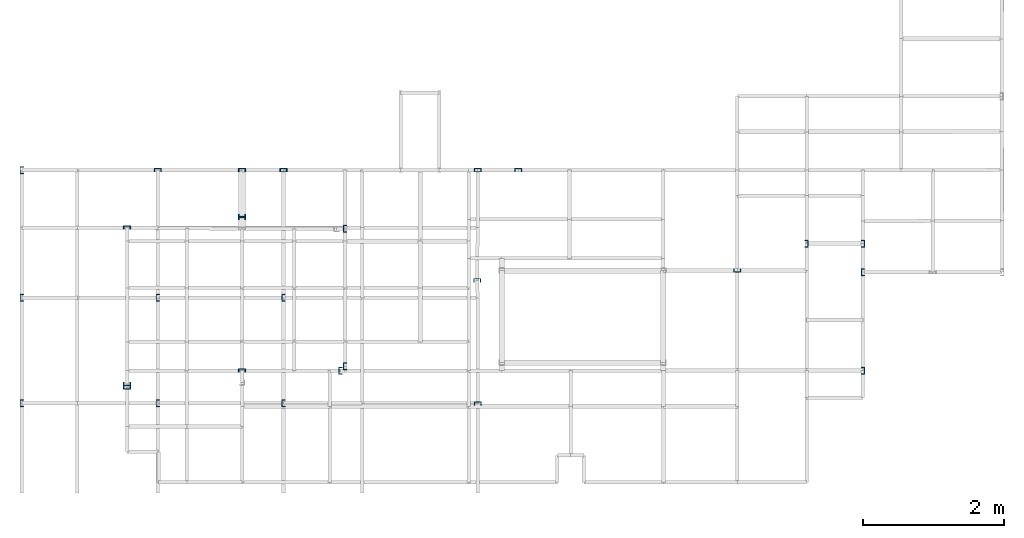
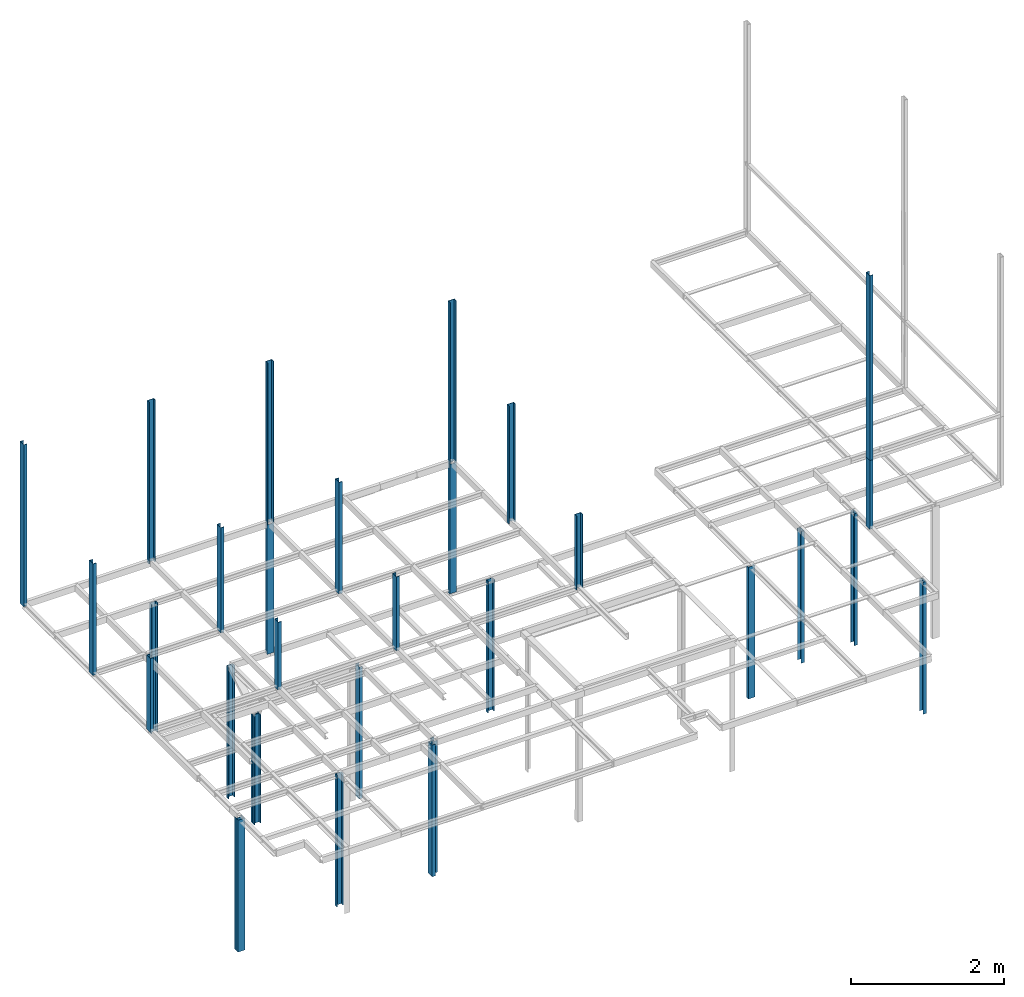
# Not in any storey, part 1 of 7: 31 columns.
"""IFC2X3 model written with IfcOpenShell, lengths in centimetres."""

from ifc_helpers import new_model, si_unit, frame, frame_2d, origin_with_axes, origin_2d_with_axis, place, context, project, u_section, extrude, material, element, save


model = new_model("IFC2X3")

# Units and contexts
model_context = context("Model", 3, precision=1e-05, world=origin_with_axes())
plan_context = context("Plan", 3, precision=1e-05, world=origin_with_axes())
ifc_project = project(units=[si_unit("LENGTHUNIT", "METRE", prefix="CENTI"), si_unit("AREAUNIT", "SQUARE_METRE", prefix="CENTI"), si_unit("VOLUMEUNIT", "CUBIC_METRE", prefix="CENTI"), si_unit("PLANEANGLEUNIT", "RADIAN"), si_unit("SOLIDANGLEUNIT", "STERADIAN"), si_unit("MASSUNIT", "GRAM"), si_unit("TIMEUNIT", "SECOND"), si_unit("THERMODYNAMICTEMPERATUREUNIT", "DEGREE_CELSIUS"), si_unit("LUMINOUSINTENSITYUNIT", "LUMEN")], contexts=[model_context, plan_context])

# Columns
ifc_material = material()
for number, where, z_axis, x_axis, name in (
    (1, (-589.100036621094, 275.0, 0.0), (0.0, 0.0, 1.0), (0.0, -1.0, 0.0), "UPN - de ala Pilar:UPN 100"),
    (2, (-197.5, 275.0, 0.0), (0.0, 0.0, 1.0), (0.0, -1.0, 0.0), "UPN - de ala Pilar:UPN 100"),
):
    element("IfcColumn", number, at=place(None, frame(where, z_axis=z_axis, x_axis=x_axis)), material=ifc_material, Name=name, context=model_context, shape_type="SweptSolid", body=[
        extrude(u_section(Depth=10.0, FlangeWidth=5.0, WebThickness=0.6, FlangeThickness=0.85, FilletRadius=0.0, EdgeRadius=0.0, FlangeSlope=0.0, CentreOfGravityInX=0.0, at=origin_2d_with_axis()), origin_with_axes(), (0.0, 0.0, 1.0), 210.0),
    ])
for number, where, z_axis, x_axis, name in (
    (3, (-589.100036621094, 210.199996948242, 0.0), (0.0, 0.0, 1.0), (0.0, 1.0, 0.0), "UPN - de ala Pilar:UPN 100"),
    (4, (-589.100036621094, 207.100006103516, 0.0), (0.0, 0.0, 1.0), (0.0, -1.0, 0.0), "UPN - de ala Pilar:UPN 100"),
):
    element("IfcColumn", number, at=place(None, frame(where, z_axis=z_axis, x_axis=x_axis)), material=ifc_material, Name=name, context=model_context, shape_type="SweptSolid", body=[
        extrude(u_section(Depth=10.0, FlangeWidth=5.0, WebThickness=0.6, FlangeThickness=0.85, FilletRadius=0.0, EdgeRadius=0.0, FlangeSlope=0.0, CentreOfGravityInX=0.0, at=origin_2d_with_axis()), origin_with_axes(), (0.0, 0.0, 1.0), 173.0),
    ])
for number, where, z_axis, x_axis, name in (
    (5, (-443.100006103516, 192.0, 0.0), (0.0, 0.0, 1.0), (1.0, 0.0, 0.0), "UPN - de ala Pilar:UPN 100"),
    (6, (211.100006103516, 171.0, 0.0), (0.0, 0.0, 1.0), (-1.0, 0.0, 0.0), "UPN - de ala Pilar:UPN 100"),
    (7, (291.100006103516, 171.0, 0.0), (0.0, 0.0, 1.0), (-1.0, 0.0, 0.0), "UPN - de ala Pilar:UPN 100"),
    (8, (113.099998474121, 132.699996948242, 0.0), (0.0, 0.0, 1.0), (0.0, 1.0, 0.0), "UPN - de ala Pilar:UPN 100"),
):
    element("IfcColumn", number, at=place(None, frame(where, z_axis=z_axis, x_axis=x_axis)), material=ifc_material, Name=name, context=model_context, shape_type="SweptSolid", body=[
        extrude(u_section(Depth=10.0, FlangeWidth=5.0, WebThickness=0.6, FlangeThickness=0.85, FilletRadius=0.0, EdgeRadius=0.0, FlangeSlope=0.0, CentreOfGravityInX=0.0, at=origin_2d_with_axis()), origin_with_axes(), (0.0, 0.0, 1.0), 210.0),
    ])
column_1_placement = place(None, frame((-443.0, -3.100000143051, 0.0), z_axis=(0.0, 0.0, 1.0), x_axis=(1.0, 0.0, 0.0)))
element("IfcColumn", 9, at=column_1_placement, material=ifc_material, Name="UPN - de ala Pilar:UPN 100", context=model_context, shape_type="SweptSolid", body=[
    extrude(u_section(Depth=10.0, FlangeWidth=5.0, WebThickness=0.6, FlangeThickness=0.85, FilletRadius=0.0, EdgeRadius=0.0, FlangeSlope=0.0, CentreOfGravityInX=0.0, at=frame_2d((0.0, -1.19209e-07), x_axis=(1.0, 0.0))), origin_with_axes(), (0.0, 0.0, 1.0), 210.0),
])
column_2_placement = place(None, frame((-589.100036621094, -9.0, 0.0), z_axis=(0.0, 0.0, 1.0), x_axis=(0.0, -1.0, 0.0)))
element("IfcColumn", 10, at=column_2_placement, material=ifc_material, Name="UPN - de ala Pilar:UPN 100", context=model_context, shape_type="SweptSolid", body=[
    extrude(u_section(Depth=10.0, FlangeWidth=5.0, WebThickness=0.6, FlangeThickness=0.85, FilletRadius=0.0, EdgeRadius=0.0, FlangeSlope=0.0, CentreOfGravityInX=0.0, at=frame_2d((-2.38419e-07, 0.0), x_axis=(1.0, 0.0))), origin_with_axes(), (0.0, 0.0, 1.0), 210.0),
])
for number, where, z_axis, x_axis, name in (
    (11, (-449.600006103516, -9.0, 0.0), (0.0, 0.0, 1.0), (1.0, 0.0, 0.0), "UPN - de ala Pilar:UPN 100"),
    (12, (291.100006103516, -9.0, 0.0), (0.0, 0.0, 1.0), (-1.0, 0.0, 0.0), "UPN - de ala Pilar:UPN 100"),
    (13, (-752.100036621094, -28.200000762939, 0.0), (0.0, 0.0, 1.0), (0.0, 1.0, 0.0), "UPN - de ala Pilar:UPN 100"),
    (14, (-752.100036621094, -33.200000762939, 0.0), (0.0, 0.0, 1.0), (0.0, 1.0, 0.0), "UPN - de ala Pilar:UPN 100"),
):
    element("IfcColumn", number, at=place(None, frame(where, z_axis=z_axis, x_axis=x_axis)), material=ifc_material, Name=name, context=model_context, shape_type="SweptSolid", body=[
        extrude(u_section(Depth=10.0, FlangeWidth=5.0, WebThickness=0.6, FlangeThickness=0.85, FilletRadius=0.0, EdgeRadius=0.0, FlangeSlope=0.0, CentreOfGravityInX=0.0, at=origin_2d_with_axis()), origin_with_axes(), (0.0, 0.0, 1.0), 210.0),
    ])
for number, where, z_axis, x_axis, name in (
    (15, (-530.299987792969, 275.0, 210.0), (0.0, 0.0, 1.0), (0.0, 1.0, 0.0), "UPN - de ala Pilar:UPN 100"),
    (16, (-255.0, 275.0, 210.0), (0.0, 0.0, 1.0), (0.0, 1.0, 0.0), "UPN - de ala Pilar:UPN 100"),
    (17, (-752.100036621094, 193.5, 210.0), (0.0, 0.0, 1.0), (0.0, -1.0, 0.0), "UPN - de ala Pilar:UPN 100"),
):
    element("IfcColumn", number, at=place(None, frame(where, z_axis=z_axis, x_axis=x_axis)), material=ifc_material, Name=name, context=model_context, shape_type="SweptSolid", body=[
        extrude(u_section(Depth=10.0, FlangeWidth=5.0, WebThickness=0.6, FlangeThickness=0.85, FilletRadius=0.0, EdgeRadius=0.0, FlangeSlope=0.0, CentreOfGravityInX=0.0, at=origin_2d_with_axis()), origin_with_axes(), (0.0, 0.0, 1.0), 206.5),
    ])
column_3_placement = place(None, frame((291.100006103516, 130.400009155273, 210.0), z_axis=(0.0, 0.0, 1.0), x_axis=(1.0, 0.0, 0.0)))
element("IfcColumn", 18, at=column_3_placement, material=ifc_material, Name="UPN - de ala Pilar:UPN 100", context=model_context, shape_type="SweptSolid", body=[
    extrude(u_section(Depth=10.0, FlangeWidth=5.0, WebThickness=0.6, FlangeThickness=0.85, FilletRadius=0.0, EdgeRadius=0.0, FlangeSlope=0.0, CentreOfGravityInX=0.0, at=origin_2d_with_axis()), origin_with_axes(), (0.0, 0.0, 1.0), 110.0),
])
column_4_placement = place(None, frame((291.100006103516, 130.400009155273, 320.0), z_axis=(0.0, 0.0, 1.0), x_axis=(1.0, 0.0, 0.0)))
element("IfcColumn", 19, at=column_4_placement, material=ifc_material, Name="UPN - de ala Pilar:UPN 100", context=model_context, shape_type="SweptSolid", body=[
    extrude(u_section(Depth=10.0, FlangeWidth=5.0, WebThickness=0.6, FlangeThickness=0.85, FilletRadius=0.0, EdgeRadius=0.0, FlangeSlope=0.0, CentreOfGravityInX=0.0, at=origin_2d_with_axis()), origin_with_axes(), (0.0, 0.0, 1.0), 294.5),
])
for number, where, z_axis, x_axis, name in (
    (20, (-901.299987792969, 275.0, 416.5), (0.0, 0.0, 1.0), (1.0, 0.0, 0.0), "UPN - de ala Pilar:UPN 100"),
    (21, (-708.5, 275.0, 416.5), (0.0, 0.0, 1.0), (0.0, -1.0, 0.0), "UPN - de ala Pilar:UPN 100"),
    (22, (-530.299987792969, 275.0, 416.5), (0.0, 0.0, 1.0), (0.0, -1.0, 0.0), "UPN - de ala Pilar:UPN 100"),
    (23, (-255.0, 275.0, 416.5), (0.0, 0.0, 1.0), (0.0, -1.0, 0.0), "UPN - de ala Pilar:UPN 100"),
):
    element("IfcColumn", number, at=place(None, frame(where, z_axis=z_axis, x_axis=x_axis)), material=ifc_material, Name=name, context=model_context, shape_type="SweptSolid", body=[
        extrude(u_section(Depth=10.0, FlangeWidth=5.0, WebThickness=0.6, FlangeThickness=0.85, FilletRadius=0.0, EdgeRadius=0.0, FlangeSlope=0.0, CentreOfGravityInX=0.0, at=origin_2d_with_axis()), origin_with_axes(), (0.0, 0.0, 1.0), 258.0),
    ])
column_5_placement = place(None, frame((-255.900009155273, 119.0, 416.5), z_axis=(0.0, 0.0, 1.0), x_axis=(0.0, -1.0, 0.0)))
element("IfcColumn", 24, at=column_5_placement, material=ifc_material, Name="UPN - de ala Pilar:UPN 100", context=model_context, shape_type="SweptSolid", body=[
    extrude(u_section(Depth=10.0, FlangeWidth=5.0, WebThickness=0.6, FlangeThickness=0.85, FilletRadius=0.0, EdgeRadius=0.0, FlangeSlope=0.0, CentreOfGravityInX=0.0, at=frame_2d((0.0, -7.629395e-06), x_axis=(1.0, 0.0))), origin_with_axes(), (0.0, 0.0, 1.0), 188.0),
])
column_6_placement = place(None, frame((-901.299987792969, 94.200004577637, 416.5), z_axis=(0.0, 0.0, 1.0), x_axis=(1.0, 0.0, 0.0)))
element("IfcColumn", 25, at=column_6_placement, material=ifc_material, Name="UPN - de ala Pilar:UPN 100", context=model_context, shape_type="SweptSolid", body=[
    extrude(u_section(Depth=10.0, FlangeWidth=5.0, WebThickness=0.6, FlangeThickness=0.85, FilletRadius=0.0, EdgeRadius=0.0, FlangeSlope=0.0, CentreOfGravityInX=0.0, at=origin_2d_with_axis()), origin_with_axes(), (0.0, 0.0, 1.0), 178.0),
])
column_7_placement = place(None, frame((-708.5, 94.200004577637, 416.5), z_axis=(0.0, 0.0, 1.0), x_axis=(1.0, 0.0, 0.0)))
element("IfcColumn", 26, at=column_7_placement, material=ifc_material, Name="UPN - de ala Pilar:UPN 100", context=model_context, shape_type="SweptSolid", body=[
    extrude(u_section(Depth=10.0, FlangeWidth=5.0, WebThickness=0.6, FlangeThickness=0.85, FilletRadius=0.0, EdgeRadius=0.0, FlangeSlope=0.0, CentreOfGravityInX=0.0, at=origin_2d_with_axis()), origin_with_axes(), (0.0, 0.0, 1.0), 168.0),
])
column_8_placement = place(None, frame((-530.299987792969, 94.200004577637, 416.5), z_axis=(0.0, 0.0, 1.0), x_axis=(1.0, 0.0, 0.0)))
element("IfcColumn", 27, at=column_8_placement, material=ifc_material, Name="UPN - de ala Pilar:UPN 100", context=model_context, shape_type="SweptSolid", body=[
    extrude(u_section(Depth=10.0, FlangeWidth=5.0, WebThickness=0.6, FlangeThickness=0.85, FilletRadius=0.0, EdgeRadius=0.0, FlangeSlope=0.0, CentreOfGravityInX=0.0, at=origin_2d_with_axis()), origin_with_axes(), (0.0, 0.0, 1.0), 178.0),
])
column_9_placement = place(None, frame((-901.299987792969, -55.5, 416.5), z_axis=(0.0, 0.0, 1.0), x_axis=(1.0, 0.0, 0.0)))
element("IfcColumn", 28, at=column_9_placement, material=ifc_material, Name="UPN - de ala Pilar:UPN 100", context=model_context, shape_type="SweptSolid", body=[
    extrude(u_section(Depth=10.0, FlangeWidth=5.0, WebThickness=0.6, FlangeThickness=0.85, FilletRadius=0.0, EdgeRadius=0.0, FlangeSlope=0.0, CentreOfGravityInX=0.0, at=origin_2d_with_axis()), origin_with_axes(), (0.0, 0.0, 1.0), 118.0),
])
column_10_placement = place(None, frame((-708.5, -55.5, 416.5), z_axis=(0.0, 0.0, 1.0), x_axis=(1.0, 0.0, 0.0)))
element("IfcColumn", 29, at=column_10_placement, material=ifc_material, Name="UPN - de ala Pilar:UPN 100", context=model_context, shape_type="SweptSolid", body=[
    extrude(u_section(Depth=10.0, FlangeWidth=5.0, WebThickness=0.6, FlangeThickness=0.85, FilletRadius=0.0, EdgeRadius=0.0, FlangeSlope=0.0, CentreOfGravityInX=0.0, at=origin_2d_with_axis()), origin_with_axes(), (0.0, 0.0, 1.0), 108.0),
])
for number, where, z_axis, x_axis, name in (
    (30, (-530.299987792969, -55.5, 416.5), (0.0, 0.0, 1.0), (1.0, 0.0, 0.0), "UPN - de ala Pilar:UPN 100"),
    (31, (-255.0, -55.5, 416.5), (0.0, 0.0, 1.0), (0.0, -1.0, 0.0), "UPN - de ala Pilar:UPN 100"),
):
    element("IfcColumn", number, at=place(None, frame(where, z_axis=z_axis, x_axis=x_axis)), material=ifc_material, Name=name, context=model_context, shape_type="SweptSolid", body=[
        extrude(u_section(Depth=10.0, FlangeWidth=5.0, WebThickness=0.6, FlangeThickness=0.85, FilletRadius=0.0, EdgeRadius=0.0, FlangeSlope=0.0, CentreOfGravityInX=0.0, at=origin_2d_with_axis()), origin_with_axes(), (0.0, 0.0, 1.0), 118.0),
    ])

save(model, "model.ifc")
